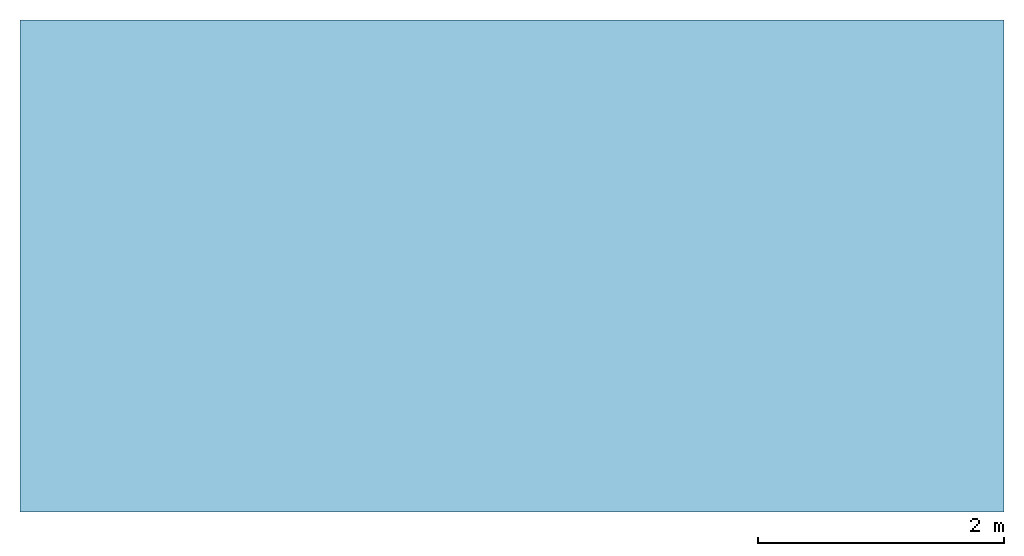
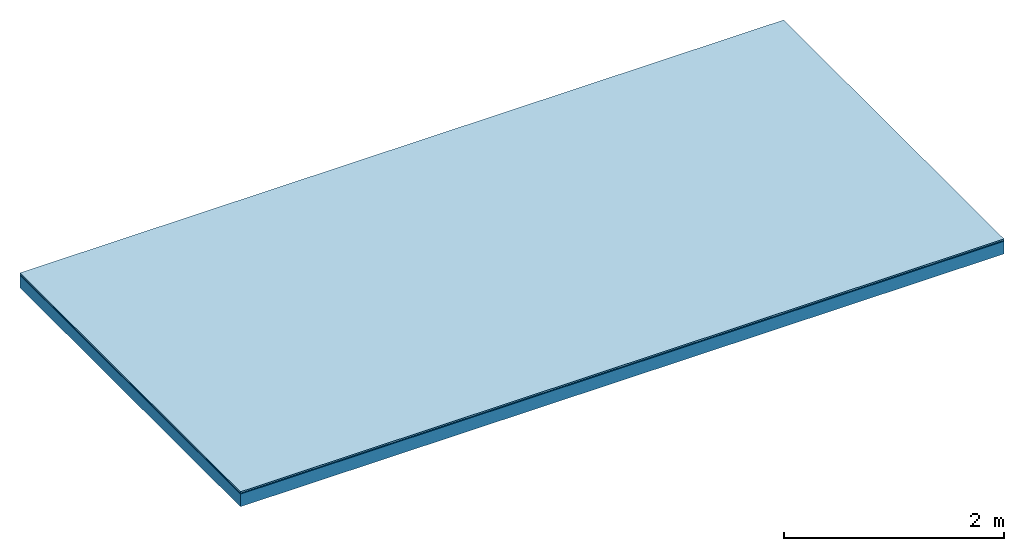
# One storey: 3 plates, 1 member, 1 element without a shape of its own.
"""IFC4 building model written with IfcOpenShell, lengths in metres."""

from ifc_helpers import new_model, si_unit, derived_unit, direction, frame, frame_2d, origin, origin_with_axes, place, context, project, spatial, rectangle, extrude, material, layer, layer_set, type_object, element, aggregate, save


model = new_model("IFC4")

# Units and contexts
plan_context = context("Plan", 3, precision=1e-05, world=origin(), true_north=direction((0.0, 1.0)))
model_context = context("Model", 3, precision=1e-05, world=origin(), true_north=direction((0.0, 1.0)))
ifc_project = project(units=[si_unit("LENGTHUNIT", "METRE"), derived_unit("SOUNDPRESSUREUNIT", [(si_unit("PRESSUREUNIT", "PASCAL", prefix="MICRO"), 0)]), si_unit("ENERGYUNIT", "JOULE", prefix="MEGA"), si_unit("MASSUNIT", "GRAM", prefix="KILO"), derived_unit("THERMALTRANSMITTANCEUNIT", [(si_unit("POWERUNIT", "WATT"), 1), (si_unit("AREAUNIT", "SQUARE_METRE"), -1), (si_unit("THERMODYNAMICTEMPERATUREUNIT", "KELVIN"), -1)]), derived_unit("AREADENSITYUNIT", [(si_unit("MASSUNIT", "GRAM", prefix="KILO"), 1), (si_unit("AREAUNIT", "SQUARE_METRE"), -1)]), derived_unit("USERDEFINED", [(si_unit("ENERGYUNIT", "JOULE", prefix="MEGA"), 1), (si_unit("AREAUNIT", "SQUARE_METRE"), -1)])], contexts=[plan_context, model_context])

# Site, building, storey
site = spatial("IfcSite", under=ifc_project)
building_placement = place(None, origin())
building = spatial("IfcBuilding", under=site, at=building_placement)
storey_placement = place(building_placement, origin())
storey = spatial("IfcBuildingStorey", under=building, at=storey_placement)

# Slab, member, plates
ifc_material_1 = material(Category="11.013")
ifc_layer_1 = layer(ifc_material_1, 0.015, Name="Flooring")
ifc_material_2 = material(Name="Wood fiber generic product", Category="10.009")
ifc_layer_2 = layer(ifc_material_2, 0.01, Name="Impact sound insulation")
ifc_material_3 = material(Name="protection", Category="09.007")
ifc_layer_3 = layer(ifc_material_3, 0.0005, Name="Sub-floor")
ifc_material_4 = material(Name="no composite action")
ifc_layer_4 = layer(ifc_material_4, 0.0, Name="Bond")
ifc_layer_5 = layer(None, 0.14, Name="Supporting structure")
ifc_layer_set = layer_set([ifc_layer_1, ifc_layer_2, ifc_layer_3, ifc_layer_4, ifc_layer_5])
slab_type = type_object("IfcSlabType", Name="A2007", PredefinedType="NOTDEFINED", material=ifc_layer_set)
slab_placement = place(None, frame((0.0, 0.0, 0.0), z_axis=(0.0, 0.0, -1.0), x_axis=(1.0, 0.0, 0.0)))
slab = element("IfcSlab", 1, at=slab_placement, inside=storey, type_object=slab_type, material=ifc_layer_set, Name="Slab #1")
ifc_material_5 = material(Name="Solid timber panel")
member_placement = place(slab_placement, origin())
member = element("IfcMember", 2, at=member_placement, material=ifc_material_5, Name="Supporting structure", context=plan_context, shape_type="SweptSolid", body=[
    extrude(rectangle(XDim=1.0, YDim=0.14, at=frame_2d((0.5, 0.07), x_axis=(1.0, 0.0))), frame((0.0, 4.0, 0.0255), z_axis=(0.0, -1.0, 0.0), x_axis=(1.0, 0.0, 0.0)), (0.0, 0.0, 1.0), 4.0),
    extrude(rectangle(XDim=1.0, YDim=0.14, at=frame_2d((0.5, 0.07), x_axis=(1.0, 0.0))), frame((1.0, 4.0, 0.0255), z_axis=(0.0, -1.0, 0.0), x_axis=(1.0, 0.0, 0.0)), (0.0, 0.0, 1.0), 4.0),
    extrude(rectangle(XDim=1.0, YDim=0.14, at=frame_2d((0.5, 0.07), x_axis=(1.0, 0.0))), frame((2.0, 4.0, 0.0255), z_axis=(0.0, -1.0, 0.0), x_axis=(1.0, 0.0, 0.0)), (0.0, 0.0, 1.0), 4.0),
    extrude(rectangle(XDim=1.0, YDim=0.14, at=frame_2d((0.5, 0.07), x_axis=(1.0, 0.0))), frame((3.0, 4.0, 0.0255), z_axis=(0.0, -1.0, 0.0), x_axis=(1.0, 0.0, 0.0)), (0.0, 0.0, 1.0), 4.0),
    extrude(rectangle(XDim=1.0, YDim=0.14, at=frame_2d((0.5, 0.07), x_axis=(1.0, 0.0))), frame((4.0, 4.0, 0.0255), z_axis=(0.0, -1.0, 0.0), x_axis=(1.0, 0.0, 0.0)), (0.0, 0.0, 1.0), 4.0),
    extrude(rectangle(XDim=1.0, YDim=0.14, at=frame_2d((0.5, 0.07), x_axis=(1.0, 0.0))), frame((5.0, 4.0, 0.0255), z_axis=(0.0, -1.0, 0.0), x_axis=(1.0, 0.0, 0.0)), (0.0, 0.0, 1.0), 4.0),
    extrude(rectangle(XDim=1.0, YDim=0.14, at=frame_2d((0.5, 0.07), x_axis=(1.0, 0.0))), frame((6.0, 4.0, 0.0255), z_axis=(0.0, -1.0, 0.0), x_axis=(1.0, 0.0, 0.0)), (0.0, 0.0, 1.0), 4.0),
    extrude(rectangle(XDim=1.0, YDim=0.14, at=frame_2d((0.5, 0.07), x_axis=(1.0, 0.0))), frame((7.0, 4.0, 0.0255), z_axis=(0.0, -1.0, 0.0), x_axis=(1.0, 0.0, 0.0)), (0.0, 0.0, 1.0), 4.0),
])
plate_1_placement = place(slab_placement, origin())
plate_1 = element("IfcPlate", 3, at=plate_1_placement, material=ifc_material_1, Name="Flooring", context=plan_context, shape_type="SweptSolid", body=[
    extrude(rectangle(XDim=8.0, YDim=4.0, at=frame_2d((4.0, 2.0), x_axis=(1.0, 0.0))), origin_with_axes(), (0.0, 0.0, 1.0), 0.015),
])
plate_2_placement = place(slab_placement, origin())
plate_2 = element("IfcPlate", 4, at=plate_2_placement, material=ifc_material_2, Name="Impact sound insulation", context=plan_context, shape_type="SweptSolid", body=[
    extrude(rectangle(XDim=8.0, YDim=4.0, at=frame_2d((4.0, 2.0), x_axis=(1.0, 0.0))), frame((0.0, 0.0, 0.015), z_axis=(0.0, 0.0, 1.0), x_axis=(1.0, 0.0, 0.0)), (0.0, 0.0, 1.0), 0.01),
])
plate_3_placement = place(slab_placement, origin())
plate_3 = element("IfcPlate", 5, at=plate_3_placement, material=ifc_material_3, Name="Sub-floor", context=plan_context, shape_type="SweptSolid", body=[
    extrude(rectangle(XDim=8.0, YDim=4.0, at=frame_2d((4.0, 2.0), x_axis=(1.0, 0.0))), frame((0.0, 0.0, 0.025), z_axis=(0.0, 0.0, 1.0), x_axis=(1.0, 0.0, 0.0)), (0.0, 0.0, 1.0), 0.0005),
])
aggregate(slab, [plate_1, plate_2, plate_3, member])

save(model, "model.ifc")
